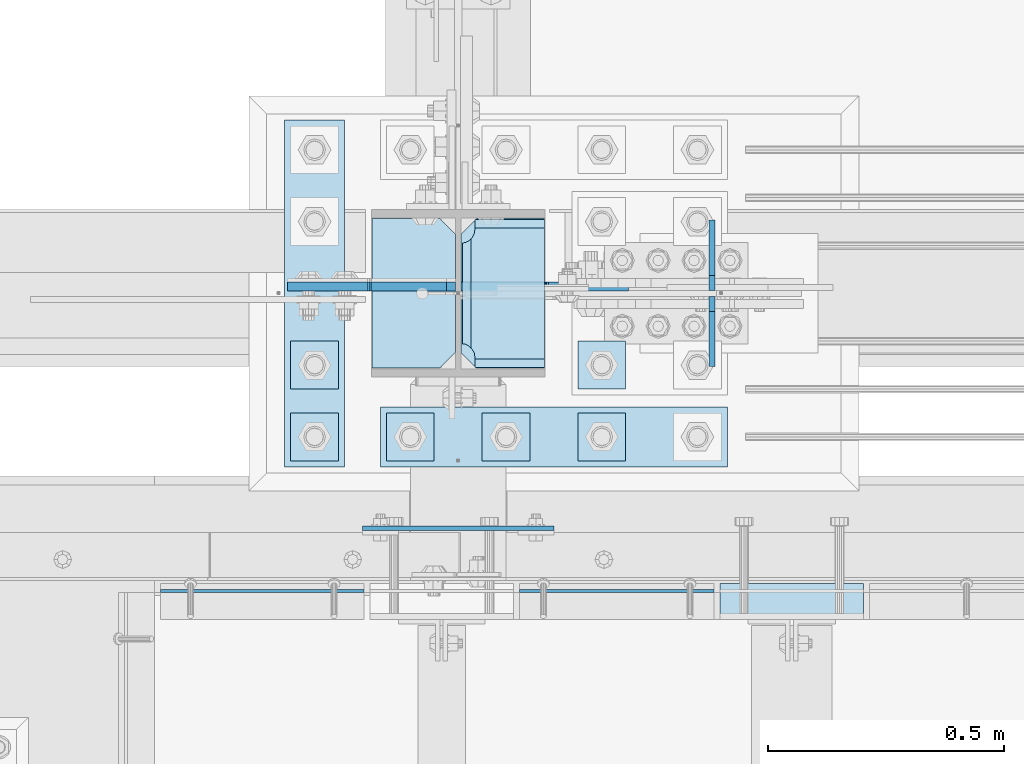
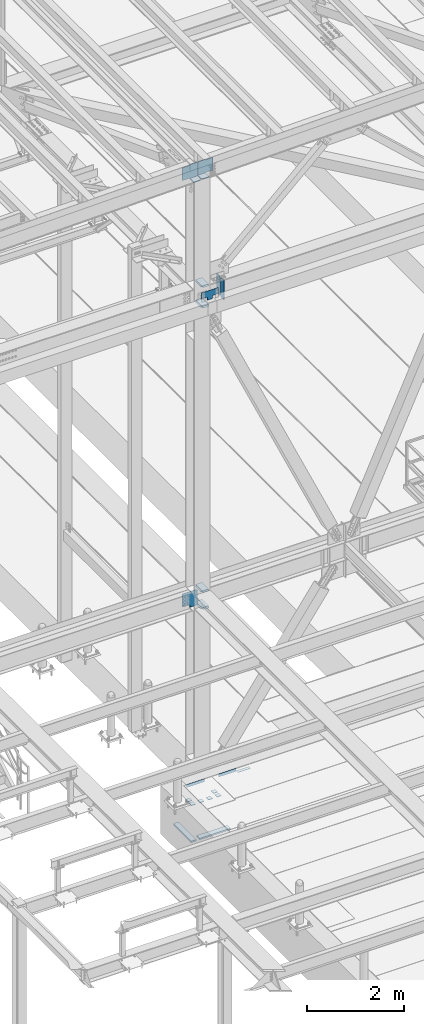
# One storey, part 3031 of 3843: 23 plates, 6 elements without a shape of their own.
"""IFC2X3 building model written with IfcOpenShell, lengths in millimetres."""

import ifcopenshell
import ifcopenshell.guid

model = None  # the IFC model being written
_history = None  # IfcOwnerHistory: only IFC2X3 demands one
_inside = {}  # id of a spatial element -> (the spatial element, [elements in it])
_under = {}  # id of a project, library or spatial element -> (it, [spatial elements below it])
_declared = {}  # id of a project -> (the project, [libraries it declares])
_typed = {}  # id of a type object -> (the type object, [elements of that type])
_made_of = {}  # id of a material, layer set ... -> (it, [elements and type objects made of it])


def new_model(schema):
    """Start an empty IFC model of exactly this schema.

    Asked for "IFC4X3", IfcOpenShell would pick the latest addendum, in which some entities
    have other attributes; the version numbers below select the first issue.
    IFC2X3 requires an IfcOwnerHistory on every rooted entity: one is made here for all.
    """
    global model, _history
    if schema == "IFC4X3":
        model = ifcopenshell.file(schema_version=(4, 3, 0, 0))
    else:
        model = ifcopenshell.file(schema=schema)
    _inside.clear()
    _under.clear()
    _declared.clear()
    _typed.clear()
    _made_of.clear()
    _history = None
    if model.schema == "IFC2X3":
        org = make("IfcOrganization", Name="unknown")
        user = make(
            "IfcPersonAndOrganization",
            ThePerson=make("IfcPerson", FamilyName="unknown"),
            TheOrganization=org,
        )
        app = make(
            "IfcApplication",
            ApplicationDeveloper=org,
            Version="unknown",
            ApplicationFullName="unknown",
            ApplicationIdentifier="unknown",
        )
        _history = make(
            "IfcOwnerHistory",
            OwningUser=user,
            OwningApplication=app,
            ChangeAction="ADDED",
            CreationDate=0,
        )
    return model


def make(cls, **values):
    """One entity of the class cls with the attributes given. An attribute that is None is left unset."""
    return model.create_entity(
        cls, **{name: value for name, value in values.items() if value is not None}
    )


def rooted(cls, **values):
    """An entity with a GlobalId (a new one), such as an element, a storey or a relation."""
    return make(cls, GlobalId=ifcopenshell.guid.new(), OwnerHistory=_history, **values)


def si_unit(unit_type, name, prefix=None):
    """IfcSIUnit, for example si_unit("LENGTHUNIT", "METRE", prefix="MILLI")."""
    return make("IfcSIUnit", UnitType=unit_type, Prefix=prefix, Name=name)


def assignment(units):
    """IfcUnitAssignment: the units of a project."""
    return None if units is None else make("IfcUnitAssignment", Units=units)


def point(xyz):
    """IfcCartesianPoint."""
    return None if xyz is None else make("IfcCartesianPoint", Coordinates=xyz)


def direction(xyz):
    """IfcDirection."""
    return None if xyz is None else make("IfcDirection", DirectionRatios=xyz)


def frame(location, z_axis=None, x_axis=None):
    """IfcAxis2Placement3D, a coordinate frame: its origin and axes. An axis left out is left unset."""
    return make(
        "IfcAxis2Placement3D",
        Location=point(location),
        Axis=direction(z_axis),
        RefDirection=direction(x_axis),
    )


def origin_with_axes():
    """The frame at (0, 0, 0) with the z axis (0, 0, 1) and the x axis (1, 0, 0) written out."""
    return frame((0.0, 0.0, 0.0), z_axis=(0.0, 0.0, 1.0), x_axis=(1.0, 0.0, 0.0))


def place(relative_to, where):
    """IfcLocalPlacement: puts the frame where relative to a parent placement (None: the world)."""
    return make(
        "IfcLocalPlacement", PlacementRelTo=relative_to, RelativePlacement=where
    )


def context(
    kind, dimensions, precision=None, world=None, true_north=None, identifier=None
):
    """IfcGeometricRepresentationContext, for example the 3D "Model" context."""
    return make(
        "IfcGeometricRepresentationContext",
        ContextIdentifier=identifier,
        ContextType=kind,
        CoordinateSpaceDimension=dimensions,
        Precision=precision,
        WorldCoordinateSystem=world,
        TrueNorth=true_north,
    )


def subcontext(parent, identifier, kind, view, scale=None):
    """IfcGeometricRepresentationSubContext, for example "Body" below "Model"."""
    return make(
        "IfcGeometricRepresentationSubContext",
        ContextIdentifier=identifier,
        ContextType=kind,
        ParentContext=parent,
        TargetScale=scale,
        TargetView=view,
    )


def project(units=None, contexts=None):
    """IfcProject with its units and contexts."""
    return rooted(
        "IfcProject",
        Name="project",
        RepresentationContexts=contexts,
        UnitsInContext=assignment(units),
    )


def spatial(cls, under=None, at=None, **own):
    """A site, building, storey or space (cls), placed at a placement, below another one or the project."""
    s = rooted(cls, ObjectPlacement=at, **own)
    if under is not None:
        _under.setdefault(under.id(), (under, []))[1].append(s)
    return s


def faces_of(points, faces, orient=None, outer=None):
    """IfcFace entities. A face is a list of loops; a loop is a list of indices into points, from 0.

    orient and outer hold one flag for each loop. By default every Orientation is true, the
    first loop of a face is its IfcFaceOuterBound and the others are IfcFaceBound.
    """
    made = []
    for i, loops in enumerate(faces):
        bounds = []
        for j, loop in enumerate(loops):
            is_outer = j == 0 if outer is None else outer[i][j]
            bounds.append(
                make(
                    "IfcFaceOuterBound" if is_outer else "IfcFaceBound",
                    Bound=make("IfcPolyLoop", Polygon=[points[k] for k in loop]),
                    Orientation=True if orient is None else orient[i][j],
                )
            )
        made.append(make("IfcFace", Bounds=bounds))
    return made


def faceted_brep(points, faces, orient=None, outer=None, voids=None):
    """IfcFacetedBrep: a solid bounded by flat faces; with voids (closed shells), ...WithVoids."""
    shared = [point(p) for p in points]
    hull = make("IfcClosedShell", CfsFaces=faces_of(shared, faces, orient, outer))
    if voids is None:
        return make("IfcFacetedBrep", Outer=hull)
    return make(
        "IfcFacetedBrepWithVoids",
        Outer=hull,
        Voids=[
            make(cls, CfsFaces=faces_of(shared, fs, o, b)) for cls, fs, o, b in voids
        ],
    )


def shape(context_of_items, identifier, shape_type, items):
    """IfcShapeRepresentation: the items that make up one representation, for example the "Body"."""
    return make(
        "IfcShapeRepresentation",
        ContextOfItems=context_of_items,
        RepresentationIdentifier=identifier,
        RepresentationType=shape_type,
        Items=items,
    )


def material(Name=None, Category=None):
    """IfcMaterial."""
    return make("IfcMaterial", Name=Name, Category=Category)


def made_of(thing, what):
    """Note that an element or type object is made of a material, layer set ...; save() writes the relation."""
    if what is not None:
        _made_of.setdefault(what.id(), (what, []))[1].append(thing)
    return thing


def type_object(cls, material=None, **own):
    """A type object (cls), such as IfcWallType, which elements share."""
    return made_of(rooted(cls, **own), material)


def element(
    cls,
    number,
    at=None,
    inside=None,
    cuts=None,
    type_object=None,
    material=None,
    context=None,
    identifier="Body",
    shape_type=None,
    held_by="IfcProductDefinitionShape",
    body=None,
    shapes=None,
    **own,
):
    """One element of the class cls, such as IfcWall. Its Tag is "e" and its number.

    at: its placement. inside: the storey or other place that contains it. cuts: it is an
    opening in that element (IfcRelVoidsElement). A single representation is given by context,
    identifier, shape_type and body (its items); several are given by shapes. held_by: the class
    of the entity that holds the representations. save() writes the other relations.
    """
    e = rooted(cls, Tag="e%d" % number, ObjectPlacement=at, **own)
    if body is not None:
        shapes = [shape(context, identifier, shape_type, body)]
    if shapes is not None:
        e.Representation = make(held_by, Representations=shapes)
    if inside is not None:
        _inside.setdefault(inside.id(), (inside, []))[1].append(e)
    if cuts is not None:
        rooted(
            "IfcRelVoidsElement", RelatingBuildingElement=cuts, RelatedOpeningElement=e
        )
    if type_object is not None:
        _typed.setdefault(type_object.id(), (type_object, []))[1].append(e)
    return made_of(e, material)


def aggregate(whole, parts):
    """IfcRelAggregates: a whole, such as a stair, and the parts it consists of."""
    return rooted("IfcRelAggregates", RelatingObject=whole, RelatedObjects=parts)


def save(model, path):
    """Write the relations noted so far, then the file.

    IfcRelAggregates (storeys below a building ...), IfcRelContainedInSpatialStructure (elements
    in a storey), IfcRelDefinesByType, IfcRelAssociatesMaterial and IfcRelDeclares: one each for
    every whole, place, type object, material and project.
    """
    for whole, parts in _under.values():
        aggregate(whole, parts)
    for where, things in _inside.values():
        rooted(
            "IfcRelContainedInSpatialStructure",
            RelatedElements=things,
            RelatingStructure=where,
        )
    for kind, things in _typed.values():
        rooted("IfcRelDefinesByType", RelatedObjects=things, RelatingType=kind)
    for what, things in _made_of.values():
        rooted("IfcRelAssociatesMaterial", RelatedObjects=things, RelatingMaterial=what)
    for by, libraries in _declared.values():
        rooted("IfcRelDeclares", RelatingContext=by, RelatedDefinitions=libraries)
    model.write(path)


model = new_model("IFC2X3")

# Units and contexts
model_context = context("Model", 3, precision=1e-05, world=origin_with_axes())
body_context = subcontext(model_context, "Body", "Model", "MODEL_VIEW")
ifc_project = project(units=[si_unit("LENGTHUNIT", "METRE", prefix="MILLI"), si_unit("AREAUNIT", "SQUARE_METRE"), si_unit("VOLUMEUNIT", "CUBIC_METRE"), si_unit("MASSUNIT", "GRAM", prefix="KILO"), si_unit("TIMEUNIT", "SECOND"), si_unit("PLANEANGLEUNIT", "RADIAN"), si_unit("SOLIDANGLEUNIT", "STERADIAN"), si_unit("THERMODYNAMICTEMPERATUREUNIT", "DEGREE_CELSIUS"), si_unit("LUMINOUSINTENSITYUNIT", "LUMEN")], contexts=[model_context])

# Site, building, storey
site_placement = place(None, origin_with_axes())
site = spatial("IfcSite", under=ifc_project, at=site_placement, CompositionType="ELEMENT")
building_placement = place(site_placement, origin_with_axes())
building = spatial("IfcBuilding", under=site, at=building_placement, Name="Undefined", CompositionType="ELEMENT")
storey_placement = place(building_placement, origin_with_axes())
storey = spatial("IfcBuildingStorey", under=building, at=storey_placement, Name="Undefined", CompositionType="ELEMENT", Elevation=0.0)

# Assembly, plate
assembly_1_placement = place(storey_placement, origin_with_axes())
assembly_1 = element("IfcElementAssembly", 1, at=assembly_1_placement, inside=storey, Name="EMBED PLATE", AssemblyPlace="NOTDEFINED", PredefinedType="RIGID_FRAME")
ifc_material_1 = material(Name="STEEL/A36")
plate_type_1 = type_object("IfcPlateType", PredefinedType="NOTDEFINED")
plate_1_placement = place(assembly_1_placement, frame((42922.825, 24923.7499969482, 30400.625), z_axis=(-1.0, 0.0, 0.0), x_axis=(0.0, 1.0, 0.0)))
plate_1 = element("IfcPlate", 2, at=plate_1_placement, type_object=plate_type_1, material=ifc_material_1, Name="PLATE", context=body_context, shape_type="Brep", body=[
    faceted_brep([(0.0, -3.17499999999927, 0.0), (0.0, -3.17499999999927, 304.800000000003), (0.0, 3.17499999999927, 304.800000000003), (0.0, 3.17499999999927, 0.0), (76.1999999999971, -3.17499999999927, 304.799999999996), (76.1999999999971, 3.17499999999927, 304.799999999996), (76.1999999999971, -3.17499999999927, 0.0), (76.1999999999971, 3.17499999999927, 0.0)], [[[0, 1, 2, 3]], [[1, 4, 5, 2]], [[4, 6, 7, 5]], [[6, 0, 3, 7]], [[5, 7, 3, 2]], [[6, 4, 1, 0]]]),
])
aggregate(assembly_1, [plate_1])

assembly_2_placement = place(storey_placement, origin_with_axes())
assembly_2 = element("IfcElementAssembly", 3, at=assembly_2_placement, inside=storey, Name="ANGLE", AssemblyPlace="NOTDEFINED", PredefinedType="RIGID_FRAME")
plate_2_placement = place(assembly_2_placement, frame((42192.5750012951, 24984.075, 30403.8000030518), z_axis=(1.0, 0.0, 0.0), x_axis=(0.0, 0.0, 1.0)))
plate_2 = element("IfcPlate", 4, at=plate_2_placement, type_object=plate_type_1, material=ifc_material_1, Name="PLATE", context=body_context, shape_type="Brep", body=[
    faceted_brep([(0.0, -3.17499999999927, 0.0), (-1.00761426438112e-05, -3.17499999982101, 412.750012208846), (-1.00761426438112e-05, 3.17500000018481, 412.750012208831), (0.0, 3.17499999999927, 0.0), (76.1999892724925, -3.17499999981919, 412.750012209093), (76.1999892724925, 3.17500000018481, 412.750012209079), (76.1999999999971, -3.17499999999927, 0.0), (76.1999999999971, 3.17499999999927, 0.0)], [[[0, 1, 2, 3]], [[1, 4, 5, 2]], [[4, 6, 7, 5]], [[6, 0, 3, 7]], [[5, 7, 3, 2]], [[6, 4, 1, 0]]]),
])
aggregate(assembly_2, [plate_2])

assembly_3_placement = place(storey_placement, origin_with_axes())
assembly_3 = element("IfcElementAssembly", 5, at=assembly_3_placement, inside=storey, Name="ANGLE", AssemblyPlace="NOTDEFINED", PredefinedType="RIGID_FRAME")
plate_3_placement = place(assembly_3_placement, frame((41430.5749990496, 24984.075, 30403.8000030518), z_axis=(1.0, 0.0, 0.0), x_axis=(0.0, 0.0, 1.0)))
plate_3 = element("IfcPlate", 6, at=plate_3_placement, type_object=plate_type_1, material=ifc_material_1, Name="PLATE", context=body_context, shape_type="Brep", body=[
    faceted_brep([(0.0, -3.17499999999927, 0.0), (-1.03997081168927e-05, -3.17499999999927, 431.799987792969), (-1.03997081168927e-05, 3.17499999999927, 431.799987792969), (0.0, 3.17499999999927, 0.0), (76.1999893189823, -3.17499999999927, 431.799987793223), (76.1999893189823, 3.17499999999927, 431.799987793223), (76.1999999999971, -3.17499999999927, 0.0), (76.1999999999971, 3.17499999999927, 0.0)], [[[0, 1, 2, 3]], [[1, 4, 5, 2]], [[4, 6, 7, 5]], [[6, 0, 3, 7]], [[5, 7, 3, 2]], [[6, 4, 1, 0]]]),
])
aggregate(assembly_3, [plate_3])

# Assembly, plates
assembly_4_placement = place(storey_placement, origin_with_axes())
assembly_4 = element("IfcElementAssembly", 7, at=assembly_4_placement, inside=storey, Name="BEAM", AssemblyPlace="NOTDEFINED", PredefinedType="RIGID_FRAME")
ifc_material_2 = material(Name="STEEL/A572-50")
plate_type_2 = type_object("IfcPlateType", PredefinedType="NOTDEFINED")
plate_4_placement = place(assembly_4_placement, frame((42601.3562561028, 25622.25, 41948.1), z_axis=(0.0, 0.0, 1.0), x_axis=(0.0, 1.0, 0.0)))
plate_4 = element("IfcPlate", 8, at=plate_4_placement, type_object=plate_type_2, material=ifc_material_2, Name="PLATE", context=body_context, shape_type="Brep", body=[
    faceted_brep([(0.0, -6.35000000000582, 31.75), (0.0, -6.35000000000582, 466.724999999999), (0.0, 6.35000000000582, 466.724999999999), (0.0, 6.35000000000582, 31.75), (31.75, -6.35000000000582, 498.474999999999), (31.75, 6.35000000000582, 498.474999999999), (149.224999999991, -6.35000000000582, 498.474999999999), (149.224999999991, 6.35000000000582, 498.474999999999), (149.224999999991, -6.35000000000582, 0.0), (149.224999999991, 6.35000000000582, 0.0), (31.75, -6.35000000000582, 0.0), (31.75, 6.35000000000582, 0.0)], [[[0, 1, 2, 3]], [[1, 4, 5, 2]], [[4, 6, 7, 5]], [[6, 8, 9, 7]], [[8, 10, 11, 9]], [[10, 0, 3, 11]], [[5, 7, 9, 11, 3, 2]], [[10, 8, 6, 4, 1, 0]]]),
])
plate_5_placement = place(assembly_4_placement, frame((42601.3562561028, 25460.325, 41948.1), z_axis=(0.0, 0.0, 1.0), x_axis=(0.0, 1.0, 0.0)))
plate_5 = element("IfcPlate", 9, at=plate_5_placement, type_object=plate_type_2, material=ifc_material_2, Name="PLATE", context=body_context, shape_type="Brep", body=[
    faceted_brep([(0.0, -6.3499999046162, 0.0), (0.0, -6.35000000000582, 498.474999999999), (0.0, 6.35000000000582, 498.474999999999), (7.27595761418343e-12, 6.3499999046162, 0.0), (117.474999999991, -6.35000000000582, 498.474999999999), (117.474999999991, 6.35000000000582, 498.474999999999), (149.224999999991, -6.35000000000582, 466.724999999999), (149.224999999991, 6.35000000000582, 466.724999999999), (149.224999999991, -6.35000000000582, 31.75), (149.224999999991, 6.35000000000582, 31.75), (117.474999999991, -6.35000000000582, 0.0), (117.474999999991, 6.35000000000582, 0.0)], [[[0, 1, 2, 3]], [[1, 4, 5, 2]], [[4, 6, 7, 5]], [[6, 8, 9, 7]], [[8, 10, 11, 9]], [[10, 0, 3, 11]], [[5, 7, 9, 11, 3, 2]], [[10, 8, 6, 4, 1, 0]]]),
])
aggregate(assembly_4, [plate_4, plate_5])

assembly_5_placement = place(storey_placement, origin_with_axes())
assembly_5 = element("IfcElementAssembly", 10, at=assembly_5_placement, inside=storey, Name="COLUMN", AssemblyPlace="NOTDEFINED", PredefinedType="RIGID_FRAME")
plate_type_3 = type_object("IfcPlateType", PredefinedType="NOTDEFINED")
plate_6_placement = place(assembly_5_placement, frame((42245.75625, 25455.5625, 41941.75), z_axis=(0.0, 1.0, 0.0), x_axis=(-1.0, 0.0, 0.0)))
plate_6 = element("IfcPlate", 11, at=plate_6_placement, type_object=plate_type_3, material=ifc_material_2, Name="PLATE", context=body_context, shape_type="Brep", body=[
    faceted_brep([(160.070927103505, 9.33349681380787, 48.2144734940957), (156.294129000915, 15.875, 44.437675391513), (156.294129000915, 15.875, 276.23732460849), (160.070927103505, 9.33349681380787, 272.460526505907), (168.479274789282, -5.2299592362906, 268.176259371801), (174.625000047687, -15.875, 267.202872116366), (174.625000047687, -15.875, 53.4721278836369), (168.479274789282, -5.2299592362906, 52.4987406282016), (147.637499618526, 15.875, 21.5063709990791), (147.637499618526, -15.875, 3.17549995230729), (0.0, -15.875, 3.17549995230729), (0.0, 15.875, 21.5063709990791), (0.0, 15.875, 299.169629000906), (0.0, -15.875, 317.500500047678), (147.637499618526, -15.875, 317.500500047678), (147.637499618526, 15.875, 299.169629000906), (147.63749961853, -15.875, 296.862501907352), (147.63749961853, 15.875, 296.862501907352), (149.113757464445, -15.875, 287.541776696642), (149.113757464445, 15.875, 287.541776696642), (153.398024598548, -15.875, 279.133429010864), (153.398024598548, 15.875, 279.133429010864), (160.070927103505, -15.875, 272.460526505907), (168.479274789282, -15.875, 268.176259371801), (168.479274789282, -15.875, 52.4987406282016), (160.070927103505, -15.875, 48.2144734940957), (153.398024598548, -15.875, 41.5415709891386), (153.398024598548, 15.875, 41.5415709891386), (149.113757464449, -15.875, 33.1332233033609), (149.113757464449, 15.875, 33.1332233033609), (147.63749961853, -15.875, 23.8124980926514), (147.63749961853, 15.875, 23.8124980926514)], [[[0, 1, 2, 3, 4, 5, 6, 7]], [[8, 9, 10, 11]], [[12, 13, 14, 15]], [[13, 12, 11, 10]], [[16, 17, 15, 14]], [[16, 18, 19, 17]], [[18, 20, 21, 19]], [[21, 20, 22, 3, 2]], [[22, 23, 4, 3]], [[23, 5, 4]], [[24, 7, 6]], [[24, 25, 0, 7]], [[25, 26, 27, 1, 0]], [[26, 28, 29, 27]], [[28, 30, 31, 29]], [[31, 30, 9, 8]], [[27, 29, 31, 8, 11, 12, 15, 17, 19, 21, 2, 1]], [[9, 30, 28, 26, 25, 24, 6, 5, 23, 22, 20, 18, 16, 14, 13, 10]]]),
])
plate_7_placement = place(assembly_5_placement, frame((42245.75625, 25455.5625, 42452.925), z_axis=(0.0, 1.0, 0.0), x_axis=(-1.0, 0.0, 0.0)))
plate_7 = element("IfcPlate", 12, at=plate_7_placement, type_object=plate_type_3, material=ifc_material_2, Name="PLATE", context=body_context, shape_type="Brep", body=[
    faceted_brep([(160.070927103505, 9.33349681380787, 48.2144734940957), (156.294129000915, 15.875, 44.437675391513), (156.294129000915, 15.875, 276.23732460849), (160.070927103505, 9.33349681380787, 272.460526505907), (168.479274789282, -5.2299592362906, 268.176259371801), (174.625000047687, -15.875, 267.202872116366), (174.625000047687, -15.875, 53.4721278836369), (168.479274789282, -5.2299592362906, 52.4987406282016), (147.637499618526, 15.875, 21.5063709990791), (147.637499618526, -15.875, 3.17549995230729), (0.0, -15.875, 3.17549995230729), (0.0, 15.875, 21.5063709990791), (0.0, 15.875, 299.169629000906), (0.0, -15.875, 317.500500047678), (147.637499618526, -15.875, 317.500500047678), (147.637499618526, 15.875, 299.169629000906), (147.63749961853, -15.875, 296.862501907352), (147.63749961853, 15.875, 296.862501907352), (149.113757464445, -15.875, 287.541776696642), (149.113757464445, 15.875, 287.541776696642), (153.398024598548, -15.875, 279.133429010864), (153.398024598548, 15.875, 279.133429010864), (160.070927103505, -15.875, 272.460526505907), (168.479274789282, -15.875, 268.176259371801), (168.479274789282, -15.875, 52.4987406282016), (160.070927103505, -15.875, 48.2144734940957), (153.398024598548, -15.875, 41.5415709891386), (153.398024598548, 15.875, 41.5415709891386), (149.113757464449, -15.875, 33.1332233033609), (149.113757464449, 15.875, 33.1332233033609), (147.63749961853, -15.875, 23.8124980926514), (147.63749961853, 15.875, 23.8124980926514)], [[[0, 1, 2, 3, 4, 5, 6, 7]], [[8, 9, 10, 11]], [[12, 13, 14, 15]], [[13, 12, 11, 10]], [[16, 17, 15, 14]], [[16, 18, 19, 17]], [[18, 20, 21, 19]], [[21, 20, 22, 3, 2]], [[22, 23, 4, 3]], [[23, 5, 4]], [[24, 7, 6]], [[24, 25, 0, 7]], [[25, 26, 27, 1, 0]], [[26, 28, 29, 27]], [[28, 30, 31, 29]], [[31, 30, 9, 8]], [[27, 29, 31, 8, 11, 12, 15, 17, 19, 21, 2, 1]], [[9, 30, 28, 26, 25, 24, 6, 5, 23, 22, 20, 18, 16, 14, 13, 10]]]),
])
plate_8_placement = place(assembly_5_placement, frame((42245.75625, 25455.5625, 34369.375), z_axis=(0.0, 1.0, 0.0), x_axis=(-1.0, 0.0, 0.0)))
plate_8 = element("IfcPlate", 13, at=plate_8_placement, type_object=plate_type_3, material=ifc_material_2, Name="PLATE", context=body_context, shape_type="Brep", body=[
    faceted_brep([(160.070930155263, 9.33338851059671, 48.2144734940957), (156.294129000915, 15.875, 44.437675391513), (156.294129000915, 15.875, 276.23732460849), (160.070930155263, 9.33338851059671, 272.460514298873), (168.479277841041, -5.23029688887618, 268.176247164767), (174.625000047687, -15.875, 267.202872116366), (174.625000047687, -15.875, 53.4721278836369), (168.479277841041, -5.23029688887618, 52.4987406282016), (147.637499618526, 15.875, 21.5063709990791), (147.637499618526, -15.875, 3.17549995230729), (0.0, -15.875, 3.17549995230729), (0.0, 15.875, 21.5063709990791), (0.0, 15.875, 299.169629000906), (0.0, -15.875, 317.500500047678), (147.637499618526, -15.875, 317.500500047678), (147.637499618526, 15.875, 299.169629000906), (147.63749961853, -15.875, 296.862501907352), (147.63749961853, 15.875, 296.862501907352), (149.113757464445, -15.875, 287.541776696642), (149.113757464445, 15.875, 287.541776696642), (153.398024598548, -15.875, 279.133429010864), (153.398024598548, 15.875, 279.133429010864), (160.070927103505, -15.875, 272.460526505907), (168.479274789282, -15.875, 268.176259371801), (168.479274789282, -15.875, 52.4987406282016), (160.070927103505, -15.875, 48.2144734940957), (153.398024598548, -15.875, 41.5415709891386), (153.398024598548, 15.875, 41.5415709891386), (149.113757464449, -15.875, 33.1332233033609), (149.113757464449, 15.875, 33.1332233033609), (147.63749961853, -15.875, 23.8124980926514), (147.63749961853, 15.875, 23.8124980926514)], [[[0, 1, 2, 3, 4, 5, 6, 7]], [[8, 9, 10, 11]], [[12, 13, 14, 15]], [[13, 12, 11, 10]], [[16, 17, 15, 14]], [[16, 18, 19, 17]], [[18, 20, 21, 19]], [[21, 20, 22, 3, 2]], [[22, 23, 4, 3]], [[23, 5, 4]], [[24, 7, 6]], [[24, 25, 0, 7]], [[25, 26, 27, 1, 0]], [[26, 28, 29, 27]], [[28, 30, 31, 29]], [[31, 30, 9, 8]], [[27, 29, 31, 8, 11, 12, 15, 17, 19, 21, 2, 1]], [[9, 30, 28, 26, 25, 24, 6, 5, 23, 22, 20, 18, 16, 14, 13, 10]]]),
])
plate_9_placement = place(assembly_5_placement, frame((42245.75625, 25455.5625, 34794.825), z_axis=(0.0, 1.0, 0.0), x_axis=(-1.0, 0.0, 0.0)))
plate_9 = element("IfcPlate", 14, at=plate_9_placement, type_object=plate_type_3, material=ifc_material_2, Name="PLATE", context=body_context, shape_type="Brep", body=[
    faceted_brep([(160.070930155263, 9.33338851059671, 48.2144734940957), (156.294129000915, 15.875, 44.437675391513), (156.294129000915, 15.875, 276.23732460849), (160.070930155263, 9.33338851059671, 272.460514298873), (168.479277841041, -5.23029688887618, 268.176247164767), (174.625000047687, -15.875, 267.202872116366), (174.625000047687, -15.875, 53.4721278836369), (168.479277841041, -5.23029688887618, 52.4987406282016), (147.637499618526, 15.875, 21.5063709990791), (147.637499618526, -15.875, 3.17549995230729), (0.0, -15.875, 3.17549995230729), (0.0, 15.875, 21.5063709990791), (0.0, 15.875, 299.169629000906), (0.0, -15.875, 317.500500047678), (147.637499618526, -15.875, 317.500500047678), (147.637499618526, 15.875, 299.169629000906), (147.63749961853, -15.875, 296.862501907352), (147.63749961853, 15.875, 296.862501907352), (149.113757464445, -15.875, 287.541776696642), (149.113757464445, 15.875, 287.541776696642), (153.398024598548, -15.875, 279.133429010864), (153.398024598548, 15.875, 279.133429010864), (160.070927103505, -15.875, 272.460526505907), (168.479274789282, -15.875, 268.176259371801), (168.479274789282, -15.875, 52.4987406282016), (160.070927103505, -15.875, 48.2144734940957), (153.398024598548, -15.875, 41.5415709891386), (153.398024598548, 15.875, 41.5415709891386), (149.113757464449, -15.875, 33.1332233033609), (149.113757464449, 15.875, 33.1332233033609), (147.63749961853, -15.875, 23.8124980926514), (147.63749961853, 15.875, 23.8124980926514)], [[[0, 1, 2, 3, 4, 5, 6, 7]], [[8, 9, 10, 11]], [[12, 13, 14, 15]], [[13, 12, 11, 10]], [[16, 17, 15, 14]], [[16, 18, 19, 17]], [[18, 20, 21, 19]], [[21, 20, 22, 3, 2]], [[22, 23, 4, 3]], [[23, 5, 4]], [[24, 7, 6]], [[24, 25, 0, 7]], [[25, 26, 27, 1, 0]], [[26, 28, 29, 27]], [[28, 30, 31, 29]], [[31, 30, 9, 8]], [[27, 29, 31, 8, 11, 12, 15, 17, 19, 21, 2, 1]], [[9, 30, 28, 26, 25, 24, 6, 5, 23, 22, 20, 18, 16, 14, 13, 10]]]),
])
plate_type_4 = type_object("IfcPlateType", PredefinedType="NOTDEFINED")
plate_10_placement = place(assembly_5_placement, frame((42245.75625, 25457.15, 45168.6339887485), z_axis=(0.0, 1.0, 0.0), x_axis=(-1.0, 0.0, 0.0)))
plate_10 = element("IfcPlate", 15, at=plate_10_placement, type_object=plate_type_4, material=ifc_material_2, Name="PLATE", context=body_context, shape_type="Brep", body=[
    faceted_brep([(0.0, -9.52500000000146, 0.0), (0.0, -9.52500000000146, 317.5), (0.0, 9.52500000000146, 317.5), (0.0, 9.52500000000146, 0.0), (144.462501525879, -9.52500000000146, 317.5), (144.462501525879, 9.52500000000146, 317.5), (177.800003051758, -9.52500000000146, 284.162498474121), (177.800003051758, 9.52500000000146, 284.162498474121), (177.800003051758, -9.52500000000146, 33.3375015258789), (177.800003051758, 9.52500000000146, 33.3375015258789), (144.462501525879, -9.52500000000146, 0.0), (144.462501525879, 9.52500000000146, 0.0)], [[[0, 1, 2, 3]], [[1, 4, 5, 2]], [[4, 6, 7, 5]], [[6, 8, 9, 7]], [[8, 10, 11, 9]], [[10, 0, 3, 11]], [[5, 7, 9, 11, 3, 2]], [[10, 8, 6, 4, 1, 0]]]),
])
plate_11_placement = place(assembly_5_placement, frame((41879.0437499988, 25774.6499999999, 45157.1295418226), z_axis=(0.0, -1.0, 0.0), x_axis=(1.0, 0.0, 0.0)))
plate_11 = element("IfcPlate", 16, at=plate_11_placement, type_object=plate_type_4, material=ifc_material_2, Name="PLATE", context=body_context, shape_type="Brep", body=[
    faceted_brep([(0.0, -9.52500000000146, 0.0), (0.0, -9.52500000000146, 317.5), (0.0, 9.52500000000146, 317.5), (0.0, 9.52500000000146, 0.0), (144.462501525879, -9.52500000000146, 317.5), (144.462501525879, 9.52500000000146, 317.5), (177.800003051758, -9.52500000000146, 284.162498474121), (177.800003051758, 9.52500000000146, 284.162498474121), (177.800003051758, -9.52500000000146, 33.3375015258789), (177.800003051758, 9.52500000000146, 33.3375015258789), (144.462501525879, -9.52500000000146, 0.0), (144.462501525879, 9.52500000000146, 0.0)], [[[0, 1, 2, 3]], [[1, 4, 5, 2]], [[4, 6, 7, 5]], [[6, 8, 9, 7]], [[8, 10, 11, 9]], [[10, 0, 3, 11]], [[5, 7, 9, 11, 3, 2]], [[10, 8, 6, 4, 1, 0]]]),
])
plate_type_5 = type_object("IfcPlateType", PredefinedType="NOTDEFINED")
plate_12_placement = place(assembly_5_placement, frame((41998.9000000001, 25117.425, 42367.2000000001), z_axis=(0.0, 0.0, 1.0), x_axis=(1.0, 0.0, 0.0)))
plate_12 = element("IfcPlate", 17, at=plate_12_placement, type_object=plate_type_5, material=ifc_material_2, Name="PLATE", context=body_context, shape_type="Brep", body=[
    faceted_brep([(0.0, -4.76249999999709, 0.0), (-3.49245965480804e-10, -4.76249999999709, 76.1999999999462), (-3.49245965480804e-10, 4.76249999999709, 76.1999999999462), (0.0, 4.76249999999709, 0.0), (-139.699996948242, -4.76249999999709, 76.1999969482422), (-139.699996948242, 4.76249999999709, 76.1999969482422), (-139.699996948242, -4.76249999999709, 228.600006103516), (-139.699996948242, 4.76249999999709, 228.600006103516), (266.700012207031, -4.76249999999709, 228.600006103516), (266.700012207031, 4.76249999999709, 228.600006103516), (266.700012207031, -4.76249999999709, 76.1999969482422), (266.700012207031, 4.76249999999709, 76.1999969482422), (126.999992370605, -4.76249999999709, 76.1999969482422), (126.999992370605, 4.76249999999709, 76.1999969482422), (126.999992370605, -4.76249999999709, 0.0), (126.999992370605, 4.76249999999709, 0.0)], [[[0, 1, 2, 3]], [[1, 4, 5, 2]], [[4, 6, 7, 5]], [[6, 8, 9, 7]], [[8, 10, 11, 9]], [[10, 12, 13, 11]], [[12, 14, 15, 13]], [[14, 0, 3, 15]], [[5, 7, 9, 11, 13, 15, 3, 2]], [[14, 12, 10, 8, 6, 4, 1, 0]]]),
])

assembly_6_placement = place(storey_placement, origin_with_axes())
assembly_6 = element("IfcElementAssembly", 18, at=assembly_6_placement, inside=storey, Name="TEMPLATE", AssemblyPlace="NOTDEFINED", PredefinedType="RIGID_FRAME")
plate_type_6 = type_object("IfcPlateType", PredefinedType="NOTDEFINED")
plate_13_placement = place(assembly_6_placement, frame((41808.4, 25361.9, 29686.25), z_axis=(-1.0, 0.0, 0.0), x_axis=(0.0, -1.0, 0.0)))
plate_13 = element("IfcPlate", 19, at=plate_13_placement, type_object=plate_type_6, material=ifc_material_2, Name="Washer Plate", context=body_context, shape_type="Brep", body=[
    faceted_brep([(0.0, -6.3499999046162, 0.0), (-1.67347025126219e-10, -6.35000000000582, 101.600000000151), (-1.67347025126219e-10, 6.35000000000582, 101.600000000151), (7.27595761418343e-12, 6.3499999046162, 0.0), (101.599998474121, -6.34999999999854, 101.599998474121), (101.599998474121, 6.34999999999854, 101.599998474121), (101.6, -6.34999999999854, 0.0), (101.6, 6.34999999999854, 0.0)], [[[0, 1, 2, 3]], [[1, 4, 5, 2]], [[4, 6, 7, 5]], [[6, 0, 3, 7]], [[5, 7, 3, 2]], [[6, 4, 1, 0]]]),
])
plate_14_placement = place(assembly_6_placement, frame((42011.6, 25361.9, 29686.25), z_axis=(-1.0, 0.0, 0.0), x_axis=(0.0, -1.0, 0.0)))
plate_14 = element("IfcPlate", 20, at=plate_14_placement, type_object=plate_type_6, material=ifc_material_2, Name="Washer Plate", context=body_context, shape_type="Brep", body=[
    faceted_brep([(0.0, -6.3499999046162, 0.0), (-1.67347025126219e-10, -6.35000000000582, 101.600000000151), (-1.67347025126219e-10, 6.35000000000582, 101.600000000151), (7.27595761418343e-12, 6.3499999046162, 0.0), (101.599998474121, -6.34999999999854, 101.599998474121), (101.599998474121, 6.34999999999854, 101.599998474121), (101.6, -6.34999999999854, 0.0), (101.6, 6.34999999999854, 0.0)], [[[0, 1, 2, 3]], [[1, 4, 5, 2]], [[4, 6, 7, 5]], [[6, 0, 3, 7]], [[5, 7, 3, 2]], [[6, 4, 1, 0]]]),
])
plate_15_placement = place(assembly_6_placement, frame((42214.8, 25361.9, 29686.25), z_axis=(-1.0, 0.0, 0.0), x_axis=(0.0, -1.0, 0.0)))
plate_15 = element("IfcPlate", 21, at=plate_15_placement, type_object=plate_type_6, material=ifc_material_2, Name="Washer Plate", context=body_context, shape_type="Brep", body=[
    faceted_brep([(0.0, -6.3499999046162, 0.0), (-1.67347025126219e-10, -6.35000000000582, 101.600000000151), (-1.67347025126219e-10, 6.35000000000582, 101.600000000151), (7.27595761418343e-12, 6.3499999046162, 0.0), (101.599998474121, -6.34999999999854, 101.599998474121), (101.599998474121, 6.34999999999854, 101.599998474121), (101.6, -6.34999999999854, 0.0), (101.6, 6.34999999999854, 0.0)], [[[0, 1, 2, 3]], [[1, 4, 5, 2]], [[4, 6, 7, 5]], [[6, 0, 3, 7]], [[5, 7, 3, 2]], [[6, 4, 1, 0]]]),
])
plate_16_placement = place(assembly_6_placement, frame((42418.0, 25361.9, 29686.25), z_axis=(-1.0, 0.0, 0.0), x_axis=(0.0, -1.0, 0.0)))
plate_16 = element("IfcPlate", 22, at=plate_16_placement, type_object=plate_type_6, material=ifc_material_2, Name="Washer Plate", context=body_context, shape_type="Brep", body=[
    faceted_brep([(0.0, -6.3499999046162, 0.0), (-1.67347025126219e-10, -6.35000000000582, 101.600000000151), (-1.67347025126219e-10, 6.35000000000582, 101.600000000151), (7.27595761418343e-12, 6.3499999046162, 0.0), (101.599998474121, -6.34999999999854, 101.599998474121), (101.599998474121, 6.34999999999854, 101.599998474121), (101.6, -6.34999999999854, 0.0), (101.6, 6.34999999999854, 0.0)], [[[0, 1, 2, 3]], [[1, 4, 5, 2]], [[4, 6, 7, 5]], [[6, 0, 3, 7]], [[5, 7, 3, 2]], [[6, 4, 1, 0]]]),
])
plate_17_placement = place(assembly_6_placement, frame((41808.4, 25514.3, 29686.25), z_axis=(-1.0, 0.0, 0.0), x_axis=(0.0, -1.0, 0.0)))
plate_17 = element("IfcPlate", 23, at=plate_17_placement, type_object=plate_type_6, material=ifc_material_2, Name="Washer Plate", context=body_context, shape_type="Brep", body=[
    faceted_brep([(0.0, -6.3499999046162, 0.0), (-1.67347025126219e-10, -6.35000000000582, 101.600000000151), (-1.67347025126219e-10, 6.35000000000582, 101.600000000151), (7.27595761418343e-12, 6.3499999046162, 0.0), (101.599998474121, -6.34999999999854, 101.599998474121), (101.599998474121, 6.34999999999854, 101.599998474121), (101.6, -6.34999999999854, 0.0), (101.6, 6.34999999999854, 0.0)], [[[0, 1, 2, 3]], [[1, 4, 5, 2]], [[4, 6, 7, 5]], [[6, 0, 3, 7]], [[5, 7, 3, 2]], [[6, 4, 1, 0]]]),
])
plate_18_placement = place(assembly_6_placement, frame((42418.0, 25514.3, 29686.25), z_axis=(-1.0, 0.0, 0.0), x_axis=(0.0, -1.0, 0.0)))
plate_18 = element("IfcPlate", 24, at=plate_18_placement, type_object=plate_type_6, material=ifc_material_2, Name="Washer Plate", context=body_context, shape_type="Brep", body=[
    faceted_brep([(0.0, -6.3499999046162, 0.0), (-1.67347025126219e-10, -6.35000000000582, 101.600000000151), (-1.67347025126219e-10, 6.35000000000582, 101.600000000151), (7.27595761418343e-12, 6.3499999046162, 0.0), (101.599998474121, -6.34999999999854, 101.599998474121), (101.599998474121, 6.34999999999854, 101.599998474121), (101.6, -6.34999999999854, 0.0), (101.6, 6.34999999999854, 0.0)], [[[0, 1, 2, 3]], [[1, 4, 5, 2]], [[4, 6, 7, 5]], [[6, 0, 3, 7]], [[5, 7, 3, 2]], [[6, 4, 1, 0]]]),
])

# Plate
plate_type_7 = type_object("IfcPlateType", PredefinedType="NOTDEFINED")
plate_19_placement = place(assembly_5_placement, frame((42056.84375, 25630.1875003815, 34404.3), z_axis=(-0.707106781186548, 0.0, 0.707106781186548), x_axis=(-0.707106781186548, 0.0, -0.707106781186548)))
plate_19 = element("IfcPlate", 25, at=plate_19_placement, type_object=plate_type_7, material=ifc_material_2, Name="PLATE", context=body_context, shape_type="Brep", body=[
    faceted_brep([(0.0, -9.52500000000146, 0.0), (-251.447171388727, -9.52500000000146, 251.447171388732), (-251.447171388727, 9.52500000000146, 251.447171388732), (0.0, 9.52500000000146, 0.0), (-251.447171388727, -9.52500000000146, 278.387939751803), (-251.447171388727, 9.52500000000146, 278.387939751803), (-12.9091181739805, -9.52500000000146, 516.92599296655), (-12.9091181739805, 9.52500000000146, 516.92599296655), (211.59728485167, -9.52500000000146, 292.419589940895), (211.59728485167, 9.52500000000146, 292.419589940895), (94.8539551434897, -9.52500000000146, 175.676260232722), (94.8539551434897, 9.52500000000146, 175.676260232722), (92.1009412430158, -9.52500000000146, 171.556083764575), (92.1009412430158, 9.52500000000146, 171.556083764575), (91.1342113204319, -9.52500000000146, 166.696004246536), (91.1342113204319, 9.52500000000146, 166.696004246536), (92.1009412430158, -9.52500000000146, 161.835924728512), (92.1009412430158, 9.52500000000146, 161.835924728512), (94.8539551434824, -9.52500000000146, 157.715748260365), (94.8539551434824, 9.52500000000146, 157.715748260365), (139.755236456211, -9.52500000000146, 112.814466211697), (139.755236456211, 9.52500000000146, 112.814466211697), (26.9407683632344, -9.52499999999964, 2.03726813197136e-10), (26.9407683632344, 9.52499999999964, 2.03726813197136e-10)], [[[0, 1, 2, 3]], [[1, 4, 5, 2]], [[4, 6, 7, 5]], [[6, 8, 9, 7]], [[8, 10, 11, 9]], [[10, 12, 13, 11]], [[12, 14, 15, 13]], [[14, 16, 17, 15]], [[16, 18, 19, 17]], [[18, 20, 21, 19]], [[20, 22, 23, 21]], [[22, 0, 3, 23]], [[5, 7, 9, 11, 13, 15, 17, 19, 21, 23, 3, 2]], [[22, 20, 18, 16, 14, 12, 10, 8, 6, 4, 1, 0]]]),
])

plate_type_8 = type_object("IfcPlateType", PredefinedType="NOTDEFINED")
plate_20_placement = place(assembly_5_placement, frame((42067.95625, 25630.1875003815, 45197.2089887226), z_axis=(0.707106781186548, 0.0, 0.707106781186548), x_axis=(0.707106781186548, 0.0, -0.707106781186548)))
plate_20 = element("IfcPlate", 26, at=plate_20_placement, type_object=plate_type_8, material=ifc_material_2, Name="PLATE", context=body_context, shape_type="Brep", body=[
    faceted_brep([(0.0, -9.52500000000146, 0.0), (-209.979301496754, -9.52500000000146, 209.979301496671), (-209.979301496754, 9.52500000000146, 209.979301496671), (0.0, 9.52500000000146, 0.0), (-209.979301496471, -9.52500000000146, 236.920069860033), (-209.979301496471, 9.52500000000146, 236.920069860033), (-97.1648339737767, -9.52500000000146, 349.734537382756), (-97.1648339737767, 9.52500000000146, 349.734537382756), (-93.3396839560301, -9.52500000000146, 345.909387365013), (-93.3396839560301, 9.52500000000146, 345.909387365013), (-89.219507487891, -9.52500000000146, 343.156373464546), (-89.219507487891, 9.52500000000146, 343.156373464546), (-84.35942796983, -9.52500000000146, 342.189643541991), (-84.35942796983, 9.52500000000146, 342.189643541991), (-79.4993484517727, -9.52500000000146, 343.15637346459), (-79.4993484517727, 9.52500000000146, 343.15637346459), (-75.3791719835863, -9.52500000000146, 345.909387365115), (-75.3791719835863, 9.52500000000146, 345.909387365115), (41.3641577270682, -9.52500000000146, 462.652717075805), (41.3641577270682, 9.52500000000146, 462.652717075805), (265.870560752759, -9.52500000000146, 238.146314050202), (265.870560752759, 9.52500000000146, 238.146314050202), (26.9407683632344, -9.52499999999964, 2.03726813197136e-10), (26.9407683632344, 9.52499999999964, 2.03726813197136e-10)], [[[0, 1, 2, 3]], [[1, 4, 5, 2]], [[4, 6, 7, 5]], [[6, 8, 9, 7]], [[8, 10, 11, 9]], [[10, 12, 13, 11]], [[12, 14, 15, 13]], [[14, 16, 17, 15]], [[16, 18, 19, 17]], [[18, 20, 21, 19]], [[20, 22, 23, 21]], [[22, 0, 3, 23]], [[5, 7, 9, 11, 13, 15, 17, 19, 21, 23, 3, 2]], [[22, 20, 18, 16, 14, 12, 10, 8, 6, 4, 1, 0]]]),
])

plate_type_9 = type_object("IfcPlateType", PredefinedType="NOTDEFINED")
plate_21_placement = place(assembly_5_placement, frame((42056.84375, 25630.1875003815, 45185.7045417415), z_axis=(-0.707106781186548, 0.0, 0.707106781186548), x_axis=(-0.707106781186548, 0.0, -0.707106781186548)))
plate_21 = element("IfcPlate", 27, at=plate_21_placement, type_object=plate_type_9, material=ifc_material_2, Name="PLATE", context=body_context, shape_type="Brep", body=[
    faceted_brep([(0.0, -9.52500000000146, 0.0), (-217.83702560261, -9.52500000000146, 217.837025602606), (-217.83702560261, 9.52500000000146, 217.837025602606), (0.0, 9.52500000000146, 0.0), (-217.837025602319, -9.52500000000146, 244.777793965968), (-217.837025602319, 9.52500000000146, 244.777793965968), (-105.02255807961, -9.52500000000146, 357.592261488677), (-105.02255807961, 9.52500000000146, 357.592261488677), (-94.254791630985, -9.52500000000146, 346.824495040062), (-94.254791630985, 9.52500000000146, 346.824495040062), (-90.1346151628532, -9.52500000000146, 344.071481139596), (-90.1346151628532, 9.52500000000146, 344.071481139596), (-85.2745356447995, -9.52500000000146, 343.104751217026), (-85.2745356447995, 9.52500000000146, 343.104751217026), (-80.4144561267167, -9.52500000000146, 344.07148113965), (-80.4144561267167, 9.52500000000146, 344.07148113965), (-76.2942796585558, -9.52500000000146, 346.824495040149), (-76.2942796585558, 9.52500000000146, 346.824495040149), (40.4490500521206, -9.52500000000146, 463.567824750826), (40.4490500521206, 9.52500000000146, 463.567824750826), (264.955453077768, -9.52500000000146, 239.061421725179), (264.955453077768, 9.52500000000146, 239.061421725179), (26.9407683632344, -9.52499999999964, 2.03726813197136e-10), (26.9407683632344, 9.52499999999964, 2.03726813197136e-10)], [[[0, 1, 2, 3]], [[1, 4, 5, 2]], [[4, 6, 7, 5]], [[6, 8, 9, 7]], [[8, 10, 11, 9]], [[10, 12, 13, 11]], [[12, 14, 15, 13]], [[14, 16, 17, 15]], [[16, 18, 19, 17]], [[18, 20, 21, 19]], [[20, 22, 23, 21]], [[22, 0, 3, 23]], [[5, 7, 9, 11, 13, 15, 17, 19, 21, 23, 3, 2]], [[22, 20, 18, 16, 14, 12, 10, 8, 6, 4, 1, 0]]]),
])

aggregate(assembly_5, [plate_6, plate_7, plate_10, plate_20, plate_11, plate_21, plate_12, plate_8, plate_9, plate_19])

plate_type_10 = type_object("IfcPlateType", PredefinedType="NOTDEFINED")
plate_22_placement = place(assembly_6_placement, frame((41694.1, 25984.2, 28784.55), z_axis=(1.0, 0.0, 0.0), x_axis=(0.0, -1.0, 0.0)))
plate_22 = element("IfcPlate", 28, at=plate_22_placement, type_object=plate_type_10, material=ifc_material_2, Name="PLATE", context=body_context, shape_type="Brep", body=[
    faceted_brep([(0.0, -19.0500000000029, 0.0), (0.0, -19.0499999999993, 127.0), (0.0, 19.0499999999993, 127.0), (0.0, 19.0500000000029, 0.0), (736.599975585938, -19.0499999999993, 127.0), (736.599975585938, 19.0499999999993, 127.0), (736.599975585938, -19.0499999999993, 0.0), (736.599975585938, 19.0499999999993, 0.0)], [[[0, 1, 2, 3]], [[1, 4, 5, 2]], [[4, 6, 7, 5]], [[6, 0, 3, 7]], [[5, 7, 3, 2]], [[6, 4, 1, 0]]]),
])

plate_23_placement = place(assembly_6_placement, frame((41897.3, 25374.6, 28784.55), z_axis=(1.0, 0.0, 0.0), x_axis=(0.0, -1.0, 0.0)))
plate_23 = element("IfcPlate", 29, at=plate_23_placement, type_object=plate_type_10, material=ifc_material_2, Name="PLATE", context=body_context, shape_type="Brep", body=[
    faceted_brep([(0.0, -19.0500000000029, 0.0), (0.0, -19.0499999999993, 736.600036621094), (0.0, 19.0499999999993, 736.600036621094), (0.0, 19.0500000000029, 0.0), (127.0, -19.0499999999993, 736.600036621094), (127.0, 19.0499999999993, 736.600036621094), (127.0, -19.0499999999993, 0.0), (127.0, 19.0499999999993, 0.0)], [[[0, 1, 2, 3]], [[1, 4, 5, 2]], [[4, 6, 7, 5]], [[6, 0, 3, 7]], [[5, 7, 3, 2]], [[6, 4, 1, 0]]]),
])

aggregate(assembly_6, [plate_22, plate_23, plate_13, plate_14, plate_15, plate_16, plate_17, plate_18])

save(model, "model.ifc")
